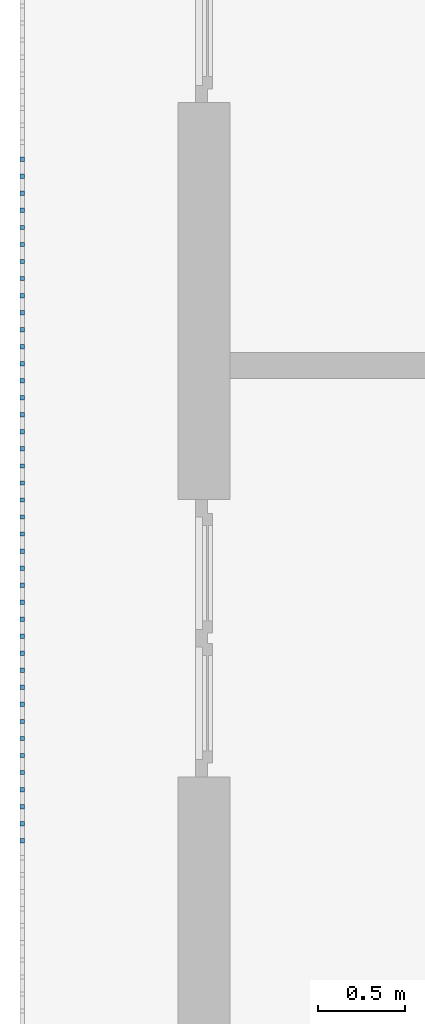
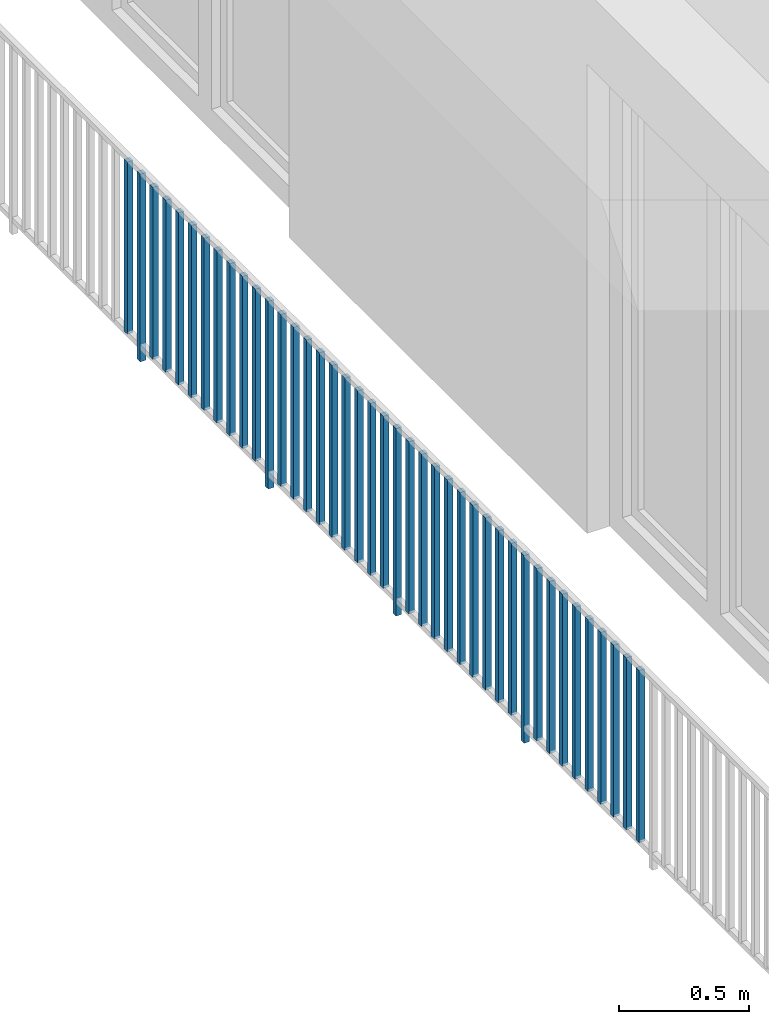
# One storey, part 34 of 54: 41 building element parts, 1 element without a shape of its own.
"""IFC4 building model written with IfcOpenShell, lengths in metres."""

from ifc_helpers import new_model, entity, si_unit, converted_unit, derived_unit, direction, frame, origin_with_axes, place, context, subcontext, project, spatial, polygons, material, type_object, element, aggregate, save


model = new_model("IFC4")

# Units and contexts
model_context = context("Model", 3, precision=1e-05, world=origin_with_axes(), true_north=direction((0.0, 1.0)))
body_context = subcontext(model_context, "Body", "Model", "MODEL_VIEW")
ifc_project = project(units=[si_unit("LENGTHUNIT", "METRE"), si_unit("AREAUNIT", "SQUARE_METRE"), si_unit("VOLUMEUNIT", "CUBIC_METRE"), converted_unit("PLANEANGLEUNIT", "DEGREE", entity("IfcPlaneAngleMeasure", 0.0174532925199), si_unit("PLANEANGLEUNIT", "RADIAN"), dimensions=[0, 0, 0, 0, 0, 0, 0]), converted_unit("TIMEUNIT", "Year", entity("IfcTimeMeasure", 31556926.0), si_unit("TIMEUNIT", "SECOND"), dimensions=[0, 0, 1, 0, 0, 0, 0]), si_unit("MASSUNIT", "GRAM", prefix="KILO"), si_unit("THERMODYNAMICTEMPERATUREUNIT", "DEGREE_CELSIUS"), si_unit("LUMINOUSINTENSITYUNIT", "LUMEN"), si_unit("ENERGYUNIT", "JOULE", prefix="MEGA"), derived_unit("THERMALCONDUCTANCEUNIT", [(si_unit("POWERUNIT", "WATT"), 1), (si_unit("LENGTHUNIT", "METRE"), -1), (si_unit("THERMODYNAMICTEMPERATUREUNIT", "KELVIN"), -1)]), derived_unit("SPECIFICHEATCAPACITYUNIT", [(si_unit("ENERGYUNIT", "JOULE"), 1), (si_unit("MASSUNIT", "GRAM", prefix="KILO"), -1), (si_unit("THERMODYNAMICTEMPERATUREUNIT", "KELVIN"), -1)]), derived_unit("MASSDENSITYUNIT", [(si_unit("MASSUNIT", "GRAM", prefix="KILO"), 1), (si_unit("VOLUMEUNIT", "CUBIC_METRE"), -1)])], contexts=[model_context])

# Site, building, storey, space
site_placement = place(None, origin_with_axes())
site = spatial("IfcSite", under=ifc_project, at=site_placement, CompositionType="ELEMENT")
building_placement = place(site_placement, origin_with_axes())
building = spatial("IfcBuilding", under=site, at=building_placement, CompositionType="ELEMENT")
storey_placement = place(building_placement, frame((0.0, 0.0, 6.29), z_axis=(0.0, 0.0, 1.0), x_axis=(1.0, 0.0, 0.0)))
storey = spatial("IfcBuildingStorey", under=building, at=storey_placement, Name="2. Geschoss", CompositionType="ELEMENT", Elevation=6.29)
space_placement = place(storey_placement, frame((10.2378006196, 9.82118769833, 0.0), z_axis=(0.0, 0.0, 1.0), x_axis=(-1.0, 0.0, 0.0)))
space = spatial("IfcSpace", under=storey, at=space_placement, CompositionType="ELEMENT", PredefinedType="EXTERNAL")

# Railing, building element parts
railing_type = type_object("IfcRailingType", PredefinedType="NOTDEFINED")
railing_placement = place(space_placement, frame((0.0, -7.06315681498e-08, 0.0), z_axis=(0.0, 0.0, 1.0), x_axis=(-1.0, 0.0, 0.0)))
railing = element("IfcRailing", 1, at=railing_placement, inside=space, type_object=railing_type, PredefinedType="NOTDEFINED")
ifc_material = material()
building_element_part_1_placement = place(railing_placement, origin_with_axes())
building_element_part_1 = element("IfcBuildingElementPart", 2, at=building_element_part_1_placement, material=ifc_material, PredefinedType="NOTDEFINED", context=body_context, shape_type="Tessellation", body=[
    polygons([(-22.8925, -12.6975, 0.07), (-22.8675, -12.6975, 0.07), (-22.8675, -12.6975, 0.8775), (-22.8925, -12.6975, 0.8775), (-22.8925, -12.6725, 0.07), (-22.8675, -12.6725, 0.07), (-22.8675, -12.6725, 0.8775), (-22.8925, -12.6725, 0.8775)], [[[1, 2, 3, 4]], [[1, 5, 6, 2]], [[2, 6, 7, 3]], [[4, 3, 7, 8]], [[5, 1, 4, 8]], [[6, 5, 8, 7]]], closed=True),
])
building_element_part_2_placement = place(railing_placement, origin_with_axes())
building_element_part_2 = element("IfcBuildingElementPart", 3, at=building_element_part_2_placement, material=ifc_material, PredefinedType="NOTDEFINED", context=body_context, shape_type="Tessellation", body=[
    polygons([(-22.8925, -12.7958333333, 0.0), (-22.8675, -12.7958333333, 0.0), (-22.8675, -12.7958333333, 0.88), (-22.8925, -12.7958333333, 0.88), (-22.8925, -12.7708333333, 0.0), (-22.8675, -12.7708333333, 0.0), (-22.8675, -12.7708333333, 0.88), (-22.8925, -12.7708333333, 0.88)], [[[1, 2, 3, 4]], [[1, 5, 6, 2]], [[2, 6, 7, 3]], [[4, 3, 7, 8]], [[5, 1, 4, 8]], [[6, 5, 8, 7]]], closed=True),
])
building_element_part_3_placement = place(railing_placement, origin_with_axes())
building_element_part_3 = element("IfcBuildingElementPart", 4, at=building_element_part_3_placement, material=ifc_material, PredefinedType="NOTDEFINED", context=body_context, shape_type="Tessellation", body=[
    polygons([(-22.8925, -12.8941666667, 0.07), (-22.8675, -12.8941666667, 0.07), (-22.8675, -12.8941666667, 0.8775), (-22.8925, -12.8941666667, 0.8775), (-22.8925, -12.8691666667, 0.07), (-22.8675, -12.8691666667, 0.07), (-22.8675, -12.8691666667, 0.8775), (-22.8925, -12.8691666667, 0.8775)], [[[1, 2, 3, 4]], [[1, 5, 6, 2]], [[2, 6, 7, 3]], [[4, 3, 7, 8]], [[5, 1, 4, 8]], [[6, 5, 8, 7]]], closed=True),
])
building_element_part_4_placement = place(railing_placement, origin_with_axes())
building_element_part_4 = element("IfcBuildingElementPart", 5, at=building_element_part_4_placement, material=ifc_material, PredefinedType="NOTDEFINED", context=body_context, shape_type="Tessellation", body=[
    polygons([(-22.8925, -12.9925, 0.07), (-22.8675, -12.9925, 0.07), (-22.8675, -12.9925, 0.8775), (-22.8925, -12.9925, 0.8775), (-22.8925, -12.9675, 0.07), (-22.8675, -12.9675, 0.07), (-22.8675, -12.9675, 0.8775), (-22.8925, -12.9675, 0.8775)], [[[1, 2, 3, 4]], [[1, 5, 6, 2]], [[2, 6, 7, 3]], [[4, 3, 7, 8]], [[5, 1, 4, 8]], [[6, 5, 8, 7]]], closed=True),
])
building_element_part_5_placement = place(railing_placement, origin_with_axes())
building_element_part_5 = element("IfcBuildingElementPart", 6, at=building_element_part_5_placement, material=ifc_material, PredefinedType="NOTDEFINED", context=body_context, shape_type="Tessellation", body=[
    polygons([(-22.8925, -13.0908333333, 0.07), (-22.8675, -13.0908333333, 0.07), (-22.8675, -13.0908333333, 0.8775), (-22.8925, -13.0908333333, 0.8775), (-22.8925, -13.0658333333, 0.07), (-22.8675, -13.0658333333, 0.07), (-22.8675, -13.0658333333, 0.8775), (-22.8925, -13.0658333333, 0.8775)], [[[1, 2, 3, 4]], [[1, 5, 6, 2]], [[2, 6, 7, 3]], [[4, 3, 7, 8]], [[5, 1, 4, 8]], [[6, 5, 8, 7]]], closed=True),
])
building_element_part_6_placement = place(railing_placement, origin_with_axes())
building_element_part_6 = element("IfcBuildingElementPart", 7, at=building_element_part_6_placement, material=ifc_material, PredefinedType="NOTDEFINED", context=body_context, shape_type="Tessellation", body=[
    polygons([(-22.8925, -13.1891666667, 0.07), (-22.8675, -13.1891666667, 0.07), (-22.8675, -13.1891666667, 0.8775), (-22.8925, -13.1891666667, 0.8775), (-22.8925, -13.1641666667, 0.07), (-22.8675, -13.1641666667, 0.07), (-22.8675, -13.1641666667, 0.8775), (-22.8925, -13.1641666667, 0.8775)], [[[1, 2, 3, 4]], [[1, 5, 6, 2]], [[2, 6, 7, 3]], [[4, 3, 7, 8]], [[5, 1, 4, 8]], [[6, 5, 8, 7]]], closed=True),
])
building_element_part_7_placement = place(railing_placement, origin_with_axes())
building_element_part_7 = element("IfcBuildingElementPart", 8, at=building_element_part_7_placement, material=ifc_material, PredefinedType="NOTDEFINED", context=body_context, shape_type="Tessellation", body=[
    polygons([(-22.8925, -13.2875, 0.07), (-22.8675, -13.2875, 0.07), (-22.8675, -13.2875, 0.8775), (-22.8925, -13.2875, 0.8775), (-22.8925, -13.2625, 0.07), (-22.8675, -13.2625, 0.07), (-22.8675, -13.2625, 0.8775), (-22.8925, -13.2625, 0.8775)], [[[1, 2, 3, 4]], [[1, 5, 6, 2]], [[2, 6, 7, 3]], [[4, 3, 7, 8]], [[5, 1, 4, 8]], [[6, 5, 8, 7]]], closed=True),
])
building_element_part_8_placement = place(railing_placement, origin_with_axes())
building_element_part_8 = element("IfcBuildingElementPart", 9, at=building_element_part_8_placement, material=ifc_material, PredefinedType="NOTDEFINED", context=body_context, shape_type="Tessellation", body=[
    polygons([(-22.8925, -13.3858333333, 0.07), (-22.8675, -13.3858333333, 0.07), (-22.8675, -13.3858333333, 0.8775), (-22.8925, -13.3858333333, 0.8775), (-22.8925, -13.3608333333, 0.07), (-22.8675, -13.3608333333, 0.07), (-22.8675, -13.3608333333, 0.8775), (-22.8925, -13.3608333333, 0.8775)], [[[1, 2, 3, 4]], [[1, 5, 6, 2]], [[2, 6, 7, 3]], [[4, 3, 7, 8]], [[5, 1, 4, 8]], [[6, 5, 8, 7]]], closed=True),
])
building_element_part_9_placement = place(railing_placement, origin_with_axes())
building_element_part_9 = element("IfcBuildingElementPart", 10, at=building_element_part_9_placement, material=ifc_material, PredefinedType="NOTDEFINED", context=body_context, shape_type="Tessellation", body=[
    polygons([(-22.8925, -13.4841666667, 0.07), (-22.8675, -13.4841666667, 0.07), (-22.8675, -13.4841666667, 0.8775), (-22.8925, -13.4841666667, 0.8775), (-22.8925, -13.4591666667, 0.07), (-22.8675, -13.4591666667, 0.07), (-22.8675, -13.4591666667, 0.8775), (-22.8925, -13.4591666667, 0.8775)], [[[1, 2, 3, 4]], [[1, 5, 6, 2]], [[2, 6, 7, 3]], [[4, 3, 7, 8]], [[5, 1, 4, 8]], [[6, 5, 8, 7]]], closed=True),
])
building_element_part_10_placement = place(railing_placement, origin_with_axes())
building_element_part_10 = element("IfcBuildingElementPart", 11, at=building_element_part_10_placement, material=ifc_material, PredefinedType="NOTDEFINED", context=body_context, shape_type="Tessellation", body=[
    polygons([(-22.8925, -13.5825, 0.07), (-22.8675, -13.5825, 0.07), (-22.8675, -13.5825, 0.8775), (-22.8925, -13.5825, 0.8775), (-22.8925, -13.5575, 0.07), (-22.8675, -13.5575, 0.07), (-22.8675, -13.5575, 0.8775), (-22.8925, -13.5575, 0.8775)], [[[1, 2, 3, 4]], [[1, 5, 6, 2]], [[2, 6, 7, 3]], [[4, 3, 7, 8]], [[5, 1, 4, 8]], [[6, 5, 8, 7]]], closed=True),
])
building_element_part_11_placement = place(railing_placement, origin_with_axes())
building_element_part_11 = element("IfcBuildingElementPart", 12, at=building_element_part_11_placement, material=ifc_material, PredefinedType="NOTDEFINED", context=body_context, shape_type="Tessellation", body=[
    polygons([(-22.8925, -13.6808333333, 0.07), (-22.8675, -13.6808333333, 0.07), (-22.8675, -13.6808333333, 0.8775), (-22.8925, -13.6808333333, 0.8775), (-22.8925, -13.6558333333, 0.07), (-22.8675, -13.6558333333, 0.07), (-22.8675, -13.6558333333, 0.8775), (-22.8925, -13.6558333333, 0.8775)], [[[1, 2, 3, 4]], [[1, 5, 6, 2]], [[2, 6, 7, 3]], [[4, 3, 7, 8]], [[5, 1, 4, 8]], [[6, 5, 8, 7]]], closed=True),
])
building_element_part_12_placement = place(railing_placement, origin_with_axes())
building_element_part_12 = element("IfcBuildingElementPart", 13, at=building_element_part_12_placement, material=ifc_material, PredefinedType="NOTDEFINED", context=body_context, shape_type="Tessellation", body=[
    polygons([(-22.8925, -13.7791666667, 0.0), (-22.8675, -13.7791666667, 0.0), (-22.8675, -13.7791666667, 0.88), (-22.8925, -13.7791666667, 0.88), (-22.8925, -13.7541666667, 0.0), (-22.8675, -13.7541666667, 0.0), (-22.8675, -13.7541666667, 0.88), (-22.8925, -13.7541666667, 0.88)], [[[1, 2, 3, 4]], [[1, 5, 6, 2]], [[2, 6, 7, 3]], [[4, 3, 7, 8]], [[5, 1, 4, 8]], [[6, 5, 8, 7]]], closed=True),
])
building_element_part_13_placement = place(railing_placement, origin_with_axes())
building_element_part_13 = element("IfcBuildingElementPart", 14, at=building_element_part_13_placement, material=ifc_material, PredefinedType="NOTDEFINED", context=body_context, shape_type="Tessellation", body=[
    polygons([(-22.8925, -13.8775, 0.07), (-22.8675, -13.8775, 0.07), (-22.8675, -13.8775, 0.8775), (-22.8925, -13.8775, 0.8775), (-22.8925, -13.8525, 0.07), (-22.8675, -13.8525, 0.07), (-22.8675, -13.8525, 0.8775), (-22.8925, -13.8525, 0.8775)], [[[1, 2, 3, 4]], [[1, 5, 6, 2]], [[2, 6, 7, 3]], [[4, 3, 7, 8]], [[5, 1, 4, 8]], [[6, 5, 8, 7]]], closed=True),
])
building_element_part_14_placement = place(railing_placement, origin_with_axes())
building_element_part_14 = element("IfcBuildingElementPart", 15, at=building_element_part_14_placement, material=ifc_material, PredefinedType="NOTDEFINED", context=body_context, shape_type="Tessellation", body=[
    polygons([(-22.8925, -13.9758333333, 0.07), (-22.8675, -13.9758333333, 0.07), (-22.8675, -13.9758333333, 0.8775), (-22.8925, -13.9758333333, 0.8775), (-22.8925, -13.9508333333, 0.07), (-22.8675, -13.9508333333, 0.07), (-22.8675, -13.9508333333, 0.8775), (-22.8925, -13.9508333333, 0.8775)], [[[1, 2, 3, 4]], [[1, 5, 6, 2]], [[2, 6, 7, 3]], [[4, 3, 7, 8]], [[5, 1, 4, 8]], [[6, 5, 8, 7]]], closed=True),
])
building_element_part_15_placement = place(railing_placement, origin_with_axes())
building_element_part_15 = element("IfcBuildingElementPart", 16, at=building_element_part_15_placement, material=ifc_material, PredefinedType="NOTDEFINED", context=body_context, shape_type="Tessellation", body=[
    polygons([(-22.8925, -14.0741666667, 0.07), (-22.8675, -14.0741666667, 0.07), (-22.8675, -14.0741666667, 0.8775), (-22.8925, -14.0741666667, 0.8775), (-22.8925, -14.0491666667, 0.07), (-22.8675, -14.0491666667, 0.07), (-22.8675, -14.0491666667, 0.8775), (-22.8925, -14.0491666667, 0.8775)], [[[1, 2, 3, 4]], [[1, 5, 6, 2]], [[2, 6, 7, 3]], [[4, 3, 7, 8]], [[5, 1, 4, 8]], [[6, 5, 8, 7]]], closed=True),
])
building_element_part_16_placement = place(railing_placement, origin_with_axes())
building_element_part_16 = element("IfcBuildingElementPart", 17, at=building_element_part_16_placement, material=ifc_material, PredefinedType="NOTDEFINED", context=body_context, shape_type="Tessellation", body=[
    polygons([(-22.8925, -14.1725, 0.07), (-22.8675, -14.1725, 0.07), (-22.8675, -14.1725, 0.8775), (-22.8925, -14.1725, 0.8775), (-22.8925, -14.1475, 0.07), (-22.8675, -14.1475, 0.07), (-22.8675, -14.1475, 0.8775), (-22.8925, -14.1475, 0.8775)], [[[1, 2, 3, 4]], [[1, 5, 6, 2]], [[2, 6, 7, 3]], [[4, 3, 7, 8]], [[5, 1, 4, 8]], [[6, 5, 8, 7]]], closed=True),
])
building_element_part_17_placement = place(railing_placement, origin_with_axes())
building_element_part_17 = element("IfcBuildingElementPart", 18, at=building_element_part_17_placement, material=ifc_material, PredefinedType="NOTDEFINED", context=body_context, shape_type="Tessellation", body=[
    polygons([(-22.8925, -14.2708333333, 0.07), (-22.8675, -14.2708333333, 0.07), (-22.8675, -14.2708333333, 0.8775), (-22.8925, -14.2708333333, 0.8775), (-22.8925, -14.2458333333, 0.07), (-22.8675, -14.2458333333, 0.07), (-22.8675, -14.2458333333, 0.8775), (-22.8925, -14.2458333333, 0.8775)], [[[1, 2, 3, 4]], [[1, 5, 6, 2]], [[2, 6, 7, 3]], [[4, 3, 7, 8]], [[5, 1, 4, 8]], [[6, 5, 8, 7]]], closed=True),
])
building_element_part_18_placement = place(railing_placement, origin_with_axes())
building_element_part_18 = element("IfcBuildingElementPart", 19, at=building_element_part_18_placement, material=ifc_material, PredefinedType="NOTDEFINED", context=body_context, shape_type="Tessellation", body=[
    polygons([(-22.8925, -14.3691666667, 0.07), (-22.8675, -14.3691666667, 0.07), (-22.8675, -14.3691666667, 0.8775), (-22.8925, -14.3691666667, 0.8775), (-22.8925, -14.3441666667, 0.07), (-22.8675, -14.3441666667, 0.07), (-22.8675, -14.3441666667, 0.8775), (-22.8925, -14.3441666667, 0.8775)], [[[1, 2, 3, 4]], [[1, 5, 6, 2]], [[2, 6, 7, 3]], [[4, 3, 7, 8]], [[5, 1, 4, 8]], [[6, 5, 8, 7]]], closed=True),
])
building_element_part_19_placement = place(railing_placement, origin_with_axes())
building_element_part_19 = element("IfcBuildingElementPart", 20, at=building_element_part_19_placement, material=ifc_material, PredefinedType="NOTDEFINED", context=body_context, shape_type="Tessellation", body=[
    polygons([(-22.8925, -14.4675, 0.07), (-22.8675, -14.4675, 0.07), (-22.8675, -14.4675, 0.8775), (-22.8925, -14.4675, 0.8775), (-22.8925, -14.4425, 0.07), (-22.8675, -14.4425, 0.07), (-22.8675, -14.4425, 0.8775), (-22.8925, -14.4425, 0.8775)], [[[1, 2, 3, 4]], [[1, 5, 6, 2]], [[2, 6, 7, 3]], [[4, 3, 7, 8]], [[5, 1, 4, 8]], [[6, 5, 8, 7]]], closed=True),
])
building_element_part_20_placement = place(railing_placement, origin_with_axes())
building_element_part_20 = element("IfcBuildingElementPart", 21, at=building_element_part_20_placement, material=ifc_material, PredefinedType="NOTDEFINED", context=body_context, shape_type="Tessellation", body=[
    polygons([(-22.8925, -14.5658333333, 0.07), (-22.8675, -14.5658333333, 0.07), (-22.8675, -14.5658333333, 0.8775), (-22.8925, -14.5658333333, 0.8775), (-22.8925, -14.5408333333, 0.07), (-22.8675, -14.5408333333, 0.07), (-22.8675, -14.5408333333, 0.8775), (-22.8925, -14.5408333333, 0.8775)], [[[1, 2, 3, 4]], [[1, 5, 6, 2]], [[2, 6, 7, 3]], [[4, 3, 7, 8]], [[5, 1, 4, 8]], [[6, 5, 8, 7]]], closed=True),
])
building_element_part_21_placement = place(railing_placement, origin_with_axes())
building_element_part_21 = element("IfcBuildingElementPart", 22, at=building_element_part_21_placement, material=ifc_material, PredefinedType="NOTDEFINED", context=body_context, shape_type="Tessellation", body=[
    polygons([(-22.8925, -14.6641666667, 0.07), (-22.8675, -14.6641666667, 0.07), (-22.8675, -14.6641666667, 0.8775), (-22.8925, -14.6641666667, 0.8775), (-22.8925, -14.6391666667, 0.07), (-22.8675, -14.6391666667, 0.07), (-22.8675, -14.6391666667, 0.8775), (-22.8925, -14.6391666667, 0.8775)], [[[1, 2, 3, 4]], [[1, 5, 6, 2]], [[2, 6, 7, 3]], [[4, 3, 7, 8]], [[5, 1, 4, 8]], [[6, 5, 8, 7]]], closed=True),
])
building_element_part_22_placement = place(railing_placement, origin_with_axes())
building_element_part_22 = element("IfcBuildingElementPart", 23, at=building_element_part_22_placement, material=ifc_material, PredefinedType="NOTDEFINED", context=body_context, shape_type="Tessellation", body=[
    polygons([(-22.8925, -14.7625, 0.0), (-22.8675, -14.7625, 0.0), (-22.8675, -14.7625, 0.88), (-22.8925, -14.7625, 0.88), (-22.8925, -14.7375, 0.0), (-22.8675, -14.7375, 0.0), (-22.8675, -14.7375, 0.88), (-22.8925, -14.7375, 0.88)], [[[1, 2, 3, 4]], [[1, 5, 6, 2]], [[2, 6, 7, 3]], [[4, 3, 7, 8]], [[5, 1, 4, 8]], [[6, 5, 8, 7]]], closed=True),
])
building_element_part_23_placement = place(railing_placement, origin_with_axes())
building_element_part_23 = element("IfcBuildingElementPart", 24, at=building_element_part_23_placement, material=ifc_material, PredefinedType="NOTDEFINED", context=body_context, shape_type="Tessellation", body=[
    polygons([(-22.8925, -14.8608333333, 0.07), (-22.8675, -14.8608333333, 0.07), (-22.8675, -14.8608333333, 0.8775), (-22.8925, -14.8608333333, 0.8775), (-22.8925, -14.8358333333, 0.07), (-22.8675, -14.8358333333, 0.07), (-22.8675, -14.8358333333, 0.8775), (-22.8925, -14.8358333333, 0.8775)], [[[1, 2, 3, 4]], [[1, 5, 6, 2]], [[2, 6, 7, 3]], [[4, 3, 7, 8]], [[5, 1, 4, 8]], [[6, 5, 8, 7]]], closed=True),
])
building_element_part_24_placement = place(railing_placement, origin_with_axes())
building_element_part_24 = element("IfcBuildingElementPart", 25, at=building_element_part_24_placement, material=ifc_material, PredefinedType="NOTDEFINED", context=body_context, shape_type="Tessellation", body=[
    polygons([(-22.8925, -14.9591666667, 0.07), (-22.8675, -14.9591666667, 0.07), (-22.8675, -14.9591666667, 0.8775), (-22.8925, -14.9591666667, 0.8775), (-22.8925, -14.9341666667, 0.07), (-22.8675, -14.9341666667, 0.07), (-22.8675, -14.9341666667, 0.8775), (-22.8925, -14.9341666667, 0.8775)], [[[1, 2, 3, 4]], [[1, 5, 6, 2]], [[2, 6, 7, 3]], [[4, 3, 7, 8]], [[5, 1, 4, 8]], [[6, 5, 8, 7]]], closed=True),
])
building_element_part_25_placement = place(railing_placement, origin_with_axes())
building_element_part_25 = element("IfcBuildingElementPart", 26, at=building_element_part_25_placement, material=ifc_material, PredefinedType="NOTDEFINED", context=body_context, shape_type="Tessellation", body=[
    polygons([(-22.8925, -15.0575, 0.07), (-22.8675, -15.0575, 0.07), (-22.8675, -15.0575, 0.8775), (-22.8925, -15.0575, 0.8775), (-22.8925, -15.0325, 0.07), (-22.8675, -15.0325, 0.07), (-22.8675, -15.0325, 0.8775), (-22.8925, -15.0325, 0.8775)], [[[1, 2, 3, 4]], [[1, 5, 6, 2]], [[2, 6, 7, 3]], [[4, 3, 7, 8]], [[5, 1, 4, 8]], [[6, 5, 8, 7]]], closed=True),
])
building_element_part_26_placement = place(railing_placement, origin_with_axes())
building_element_part_26 = element("IfcBuildingElementPart", 27, at=building_element_part_26_placement, material=ifc_material, PredefinedType="NOTDEFINED", context=body_context, shape_type="Tessellation", body=[
    polygons([(-22.8925, -15.1558333333, 0.07), (-22.8675, -15.1558333333, 0.07), (-22.8675, -15.1558333333, 0.8775), (-22.8925, -15.1558333333, 0.8775), (-22.8925, -15.1308333333, 0.07), (-22.8675, -15.1308333333, 0.07), (-22.8675, -15.1308333333, 0.8775), (-22.8925, -15.1308333333, 0.8775)], [[[1, 2, 3, 4]], [[1, 5, 6, 2]], [[2, 6, 7, 3]], [[4, 3, 7, 8]], [[5, 1, 4, 8]], [[6, 5, 8, 7]]], closed=True),
])
building_element_part_27_placement = place(railing_placement, origin_with_axes())
building_element_part_27 = element("IfcBuildingElementPart", 28, at=building_element_part_27_placement, material=ifc_material, PredefinedType="NOTDEFINED", context=body_context, shape_type="Tessellation", body=[
    polygons([(-22.8925, -15.2541666667, 0.07), (-22.8675, -15.2541666667, 0.07), (-22.8675, -15.2541666667, 0.8775), (-22.8925, -15.2541666667, 0.8775), (-22.8925, -15.2291666667, 0.07), (-22.8675, -15.2291666667, 0.07), (-22.8675, -15.2291666667, 0.8775), (-22.8925, -15.2291666667, 0.8775)], [[[1, 2, 3, 4]], [[1, 5, 6, 2]], [[2, 6, 7, 3]], [[4, 3, 7, 8]], [[5, 1, 4, 8]], [[6, 5, 8, 7]]], closed=True),
])
building_element_part_28_placement = place(railing_placement, origin_with_axes())
building_element_part_28 = element("IfcBuildingElementPart", 29, at=building_element_part_28_placement, material=ifc_material, PredefinedType="NOTDEFINED", context=body_context, shape_type="Tessellation", body=[
    polygons([(-22.8925, -15.3525, 0.07), (-22.8675, -15.3525, 0.07), (-22.8675, -15.3525, 0.8775), (-22.8925, -15.3525, 0.8775), (-22.8925, -15.3275, 0.07), (-22.8675, -15.3275, 0.07), (-22.8675, -15.3275, 0.8775), (-22.8925, -15.3275, 0.8775)], [[[1, 2, 3, 4]], [[1, 5, 6, 2]], [[2, 6, 7, 3]], [[4, 3, 7, 8]], [[5, 1, 4, 8]], [[6, 5, 8, 7]]], closed=True),
])
building_element_part_29_placement = place(railing_placement, origin_with_axes())
building_element_part_29 = element("IfcBuildingElementPart", 30, at=building_element_part_29_placement, material=ifc_material, PredefinedType="NOTDEFINED", context=body_context, shape_type="Tessellation", body=[
    polygons([(-22.8925, -15.4508333333, 0.07), (-22.8675, -15.4508333333, 0.07), (-22.8675, -15.4508333333, 0.8775), (-22.8925, -15.4508333333, 0.8775), (-22.8925, -15.4258333333, 0.07), (-22.8675, -15.4258333333, 0.07), (-22.8675, -15.4258333333, 0.8775), (-22.8925, -15.4258333333, 0.8775)], [[[1, 2, 3, 4]], [[1, 5, 6, 2]], [[2, 6, 7, 3]], [[4, 3, 7, 8]], [[5, 1, 4, 8]], [[6, 5, 8, 7]]], closed=True),
])
building_element_part_30_placement = place(railing_placement, origin_with_axes())
building_element_part_30 = element("IfcBuildingElementPart", 31, at=building_element_part_30_placement, material=ifc_material, PredefinedType="NOTDEFINED", context=body_context, shape_type="Tessellation", body=[
    polygons([(-22.8925, -15.5491666667, 0.07), (-22.8675, -15.5491666667, 0.07), (-22.8675, -15.5491666667, 0.8775), (-22.8925, -15.5491666667, 0.8775), (-22.8925, -15.5241666667, 0.07), (-22.8675, -15.5241666667, 0.07), (-22.8675, -15.5241666667, 0.8775), (-22.8925, -15.5241666667, 0.8775)], [[[1, 2, 3, 4]], [[1, 5, 6, 2]], [[2, 6, 7, 3]], [[4, 3, 7, 8]], [[5, 1, 4, 8]], [[6, 5, 8, 7]]], closed=True),
])
building_element_part_31_placement = place(railing_placement, origin_with_axes())
building_element_part_31 = element("IfcBuildingElementPart", 32, at=building_element_part_31_placement, material=ifc_material, PredefinedType="NOTDEFINED", context=body_context, shape_type="Tessellation", body=[
    polygons([(-22.8925, -15.6475, 0.07), (-22.8675, -15.6475, 0.07), (-22.8675, -15.6475, 0.8775), (-22.8925, -15.6475, 0.8775), (-22.8925, -15.6225, 0.07), (-22.8675, -15.6225, 0.07), (-22.8675, -15.6225, 0.8775), (-22.8925, -15.6225, 0.8775)], [[[1, 2, 3, 4]], [[1, 5, 6, 2]], [[2, 6, 7, 3]], [[4, 3, 7, 8]], [[5, 1, 4, 8]], [[6, 5, 8, 7]]], closed=True),
])
building_element_part_32_placement = place(railing_placement, origin_with_axes())
building_element_part_32 = element("IfcBuildingElementPart", 33, at=building_element_part_32_placement, material=ifc_material, PredefinedType="NOTDEFINED", context=body_context, shape_type="Tessellation", body=[
    polygons([(-22.8925, -15.7458333333, 0.0), (-22.8675, -15.7458333333, 0.0), (-22.8675, -15.7458333333, 0.88), (-22.8925, -15.7458333333, 0.88), (-22.8925, -15.7208333333, 0.0), (-22.8675, -15.7208333333, 0.0), (-22.8675, -15.7208333333, 0.88), (-22.8925, -15.7208333333, 0.88)], [[[1, 2, 3, 4]], [[1, 5, 6, 2]], [[2, 6, 7, 3]], [[4, 3, 7, 8]], [[5, 1, 4, 8]], [[6, 5, 8, 7]]], closed=True),
])
building_element_part_33_placement = place(railing_placement, origin_with_axes())
building_element_part_33 = element("IfcBuildingElementPart", 34, at=building_element_part_33_placement, material=ifc_material, PredefinedType="NOTDEFINED", context=body_context, shape_type="Tessellation", body=[
    polygons([(-22.8925, -15.8441666667, 0.07), (-22.8675, -15.8441666667, 0.07), (-22.8675, -15.8441666667, 0.8775), (-22.8925, -15.8441666667, 0.8775), (-22.8925, -15.8191666667, 0.07), (-22.8675, -15.8191666667, 0.07), (-22.8675, -15.8191666667, 0.8775), (-22.8925, -15.8191666667, 0.8775)], [[[1, 2, 3, 4]], [[1, 5, 6, 2]], [[2, 6, 7, 3]], [[4, 3, 7, 8]], [[5, 1, 4, 8]], [[6, 5, 8, 7]]], closed=True),
])
building_element_part_34_placement = place(railing_placement, origin_with_axes())
building_element_part_34 = element("IfcBuildingElementPart", 35, at=building_element_part_34_placement, material=ifc_material, PredefinedType="NOTDEFINED", context=body_context, shape_type="Tessellation", body=[
    polygons([(-22.8925, -15.9425, 0.07), (-22.8675, -15.9425, 0.07), (-22.8675, -15.9425, 0.8775), (-22.8925, -15.9425, 0.8775), (-22.8925, -15.9175, 0.07), (-22.8675, -15.9175, 0.07), (-22.8675, -15.9175, 0.8775), (-22.8925, -15.9175, 0.8775)], [[[1, 2, 3, 4]], [[1, 5, 6, 2]], [[2, 6, 7, 3]], [[4, 3, 7, 8]], [[5, 1, 4, 8]], [[6, 5, 8, 7]]], closed=True),
])
building_element_part_35_placement = place(railing_placement, origin_with_axes())
building_element_part_35 = element("IfcBuildingElementPart", 36, at=building_element_part_35_placement, material=ifc_material, PredefinedType="NOTDEFINED", context=body_context, shape_type="Tessellation", body=[
    polygons([(-22.8925, -16.0408333333, 0.07), (-22.8675, -16.0408333333, 0.07), (-22.8675, -16.0408333333, 0.8775), (-22.8925, -16.0408333333, 0.8775), (-22.8925, -16.0158333333, 0.07), (-22.8675, -16.0158333333, 0.07), (-22.8675, -16.0158333333, 0.8775), (-22.8925, -16.0158333333, 0.8775)], [[[1, 2, 3, 4]], [[1, 5, 6, 2]], [[2, 6, 7, 3]], [[4, 3, 7, 8]], [[5, 1, 4, 8]], [[6, 5, 8, 7]]], closed=True),
])
building_element_part_36_placement = place(railing_placement, origin_with_axes())
building_element_part_36 = element("IfcBuildingElementPart", 37, at=building_element_part_36_placement, material=ifc_material, PredefinedType="NOTDEFINED", context=body_context, shape_type="Tessellation", body=[
    polygons([(-22.8925, -16.1391666667, 0.07), (-22.8675, -16.1391666667, 0.07), (-22.8675, -16.1391666667, 0.8775), (-22.8925, -16.1391666667, 0.8775), (-22.8925, -16.1141666667, 0.07), (-22.8675, -16.1141666667, 0.07), (-22.8675, -16.1141666667, 0.8775), (-22.8925, -16.1141666667, 0.8775)], [[[1, 2, 3, 4]], [[1, 5, 6, 2]], [[2, 6, 7, 3]], [[4, 3, 7, 8]], [[5, 1, 4, 8]], [[6, 5, 8, 7]]], closed=True),
])
building_element_part_37_placement = place(railing_placement, origin_with_axes())
building_element_part_37 = element("IfcBuildingElementPart", 38, at=building_element_part_37_placement, material=ifc_material, PredefinedType="NOTDEFINED", context=body_context, shape_type="Tessellation", body=[
    polygons([(-22.8925, -16.2375, 0.07), (-22.8675, -16.2375, 0.07), (-22.8675, -16.2375, 0.8775), (-22.8925, -16.2375, 0.8775), (-22.8925, -16.2125, 0.07), (-22.8675, -16.2125, 0.07), (-22.8675, -16.2125, 0.8775), (-22.8925, -16.2125, 0.8775)], [[[1, 2, 3, 4]], [[1, 5, 6, 2]], [[2, 6, 7, 3]], [[4, 3, 7, 8]], [[5, 1, 4, 8]], [[6, 5, 8, 7]]], closed=True),
])
building_element_part_38_placement = place(railing_placement, origin_with_axes())
building_element_part_38 = element("IfcBuildingElementPart", 39, at=building_element_part_38_placement, material=ifc_material, PredefinedType="NOTDEFINED", context=body_context, shape_type="Tessellation", body=[
    polygons([(-22.8925, -16.3358333333, 0.07), (-22.8675, -16.3358333333, 0.07), (-22.8675, -16.3358333333, 0.8775), (-22.8925, -16.3358333333, 0.8775), (-22.8925, -16.3108333333, 0.07), (-22.8675, -16.3108333333, 0.07), (-22.8675, -16.3108333333, 0.8775), (-22.8925, -16.3108333333, 0.8775)], [[[1, 2, 3, 4]], [[1, 5, 6, 2]], [[2, 6, 7, 3]], [[4, 3, 7, 8]], [[5, 1, 4, 8]], [[6, 5, 8, 7]]], closed=True),
])
building_element_part_39_placement = place(railing_placement, origin_with_axes())
building_element_part_39 = element("IfcBuildingElementPart", 40, at=building_element_part_39_placement, material=ifc_material, PredefinedType="NOTDEFINED", context=body_context, shape_type="Tessellation", body=[
    polygons([(-22.8925, -16.4341666667, 0.07), (-22.8675, -16.4341666667, 0.07), (-22.8675, -16.4341666667, 0.8775), (-22.8925, -16.4341666667, 0.8775), (-22.8925, -16.4091666667, 0.07), (-22.8675, -16.4091666667, 0.07), (-22.8675, -16.4091666667, 0.8775), (-22.8925, -16.4091666667, 0.8775)], [[[1, 2, 3, 4]], [[1, 5, 6, 2]], [[2, 6, 7, 3]], [[4, 3, 7, 8]], [[5, 1, 4, 8]], [[6, 5, 8, 7]]], closed=True),
])
building_element_part_40_placement = place(railing_placement, origin_with_axes())
building_element_part_40 = element("IfcBuildingElementPart", 41, at=building_element_part_40_placement, material=ifc_material, PredefinedType="NOTDEFINED", context=body_context, shape_type="Tessellation", body=[
    polygons([(-22.8925, -16.5325, 0.07), (-22.8675, -16.5325, 0.07), (-22.8675, -16.5325, 0.8775), (-22.8925, -16.5325, 0.8775), (-22.8925, -16.5075, 0.07), (-22.8675, -16.5075, 0.07), (-22.8675, -16.5075, 0.8775), (-22.8925, -16.5075, 0.8775)], [[[1, 2, 3, 4]], [[1, 5, 6, 2]], [[2, 6, 7, 3]], [[4, 3, 7, 8]], [[5, 1, 4, 8]], [[6, 5, 8, 7]]], closed=True),
])
building_element_part_41_placement = place(railing_placement, origin_with_axes())
building_element_part_41 = element("IfcBuildingElementPart", 42, at=building_element_part_41_placement, material=ifc_material, PredefinedType="NOTDEFINED", context=body_context, shape_type="Tessellation", body=[
    polygons([(-22.8925, -16.6308333333, 0.07), (-22.8675, -16.6308333333, 0.07), (-22.8675, -16.6308333333, 0.8775), (-22.8925, -16.6308333333, 0.8775), (-22.8925, -16.6058333333, 0.07), (-22.8675, -16.6058333333, 0.07), (-22.8675, -16.6058333333, 0.8775), (-22.8925, -16.6058333333, 0.8775)], [[[1, 2, 3, 4]], [[1, 5, 6, 2]], [[2, 6, 7, 3]], [[4, 3, 7, 8]], [[5, 1, 4, 8]], [[6, 5, 8, 7]]], closed=True),
])
aggregate(railing, [building_element_part_1, building_element_part_2, building_element_part_3, building_element_part_4, building_element_part_5, building_element_part_6, building_element_part_7, building_element_part_8, building_element_part_9, building_element_part_10, building_element_part_11, building_element_part_12, building_element_part_13, building_element_part_14, building_element_part_15, building_element_part_16, building_element_part_17, building_element_part_18, building_element_part_19, building_element_part_20, building_element_part_21, building_element_part_22, building_element_part_23, building_element_part_24, building_element_part_25, building_element_part_26, building_element_part_27, building_element_part_28, building_element_part_29, building_element_part_30, building_element_part_31, building_element_part_32, building_element_part_33, building_element_part_34, building_element_part_35, building_element_part_36, building_element_part_37, building_element_part_38, building_element_part_39, building_element_part_40, building_element_part_41])

save(model, "model.ifc")
